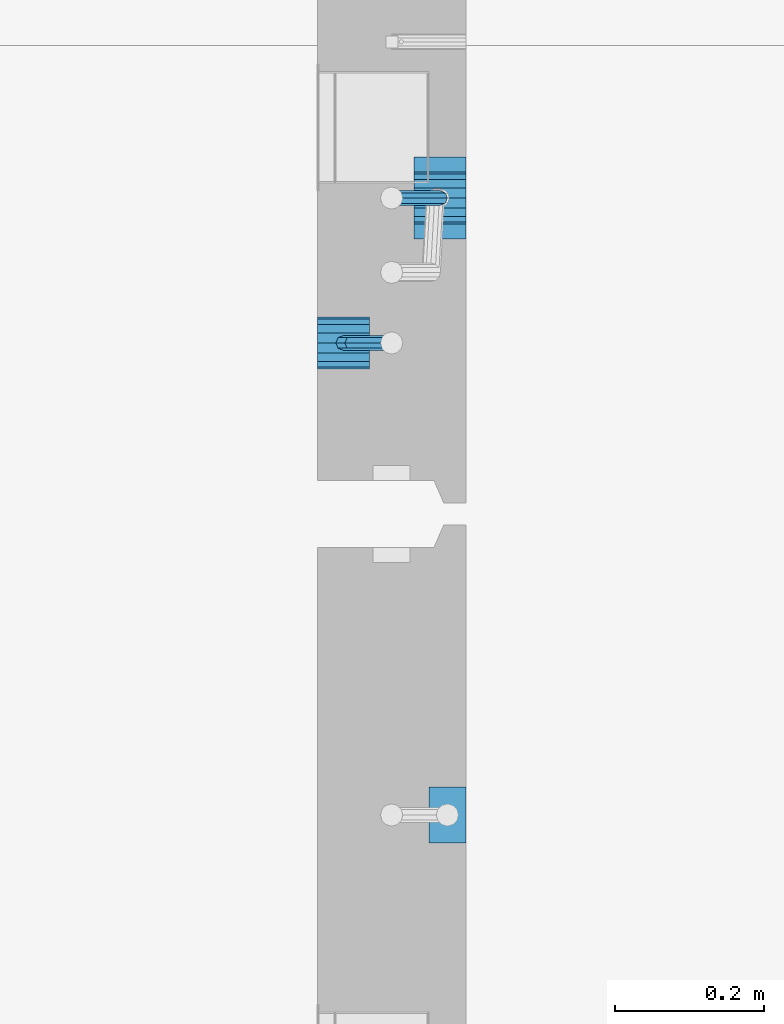
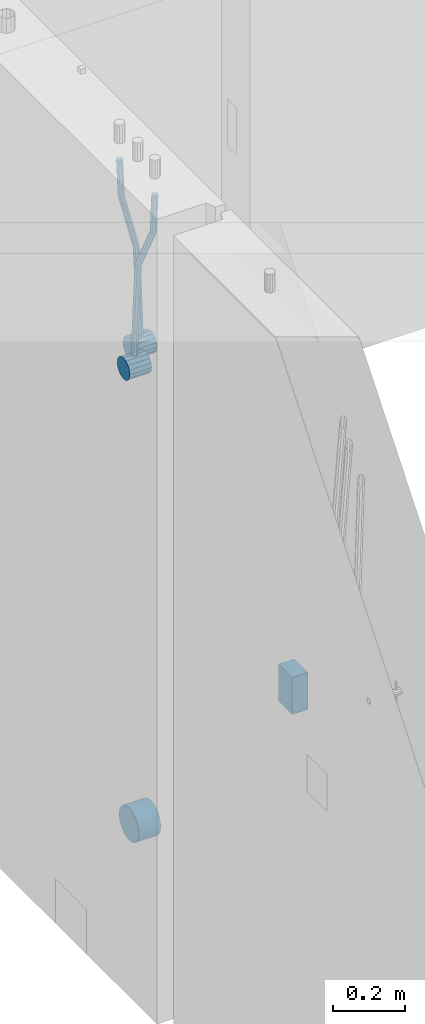
# One storey, part 148 of 350: 6 beams, 2 elements without a shape of their own.
"""IFC2X3 building model written with IfcOpenShell, lengths in millimetres."""

from ifc_helpers import new_model, si_unit, frame, origin_with_axes, place, context, subcontext, project, spatial, faceted_brep, material, type_object, element, aggregate, save


model = new_model("IFC2X3")

# Units and contexts
model_context = context("Model", 3, precision=1e-05, world=origin_with_axes())
body_context = subcontext(model_context, "Body", "Model", "MODEL_VIEW")
ifc_project = project(units=[si_unit("LENGTHUNIT", "METRE", prefix="MILLI"), si_unit("AREAUNIT", "SQUARE_METRE"), si_unit("VOLUMEUNIT", "CUBIC_METRE"), si_unit("MASSUNIT", "GRAM", prefix="KILO"), si_unit("TIMEUNIT", "SECOND"), si_unit("PLANEANGLEUNIT", "RADIAN"), si_unit("SOLIDANGLEUNIT", "STERADIAN"), si_unit("THERMODYNAMICTEMPERATUREUNIT", "DEGREE_CELSIUS"), si_unit("LUMINOUSINTENSITYUNIT", "LUMEN")], contexts=[model_context])

# Site, building, storey
site_placement = place(None, origin_with_axes())
site = spatial("IfcSite", under=ifc_project, at=site_placement, CompositionType="ELEMENT")
building_placement = place(site_placement, origin_with_axes())
building = spatial("IfcBuilding", under=site, at=building_placement, CompositionType="ELEMENT")
storey_placement = place(building_placement, origin_with_axes())
storey = spatial("IfcBuildingStorey", under=building, at=storey_placement, Name="2", CompositionType="ELEMENT", Elevation=0.0)

# Assembly, beams
assembly_1_placement = place(storey_placement, origin_with_axes())
assembly_1 = element("IfcElementAssembly", 1, at=assembly_1_placement, inside=storey, AssemblyPlace="NOTDEFINED", PredefinedType="REINFORCEMENT_UNIT")
ifc_material = material()
beam_type_1 = type_object("IfcBeamType", Name="D20", PredefinedType="NOTDEFINED")
beam_1_placement = place(assembly_1_placement, frame((21875.0000022791, 12925.0000000039, 86795.0), z_axis=(-0.999642804636942, -0.000205726999925762, -0.0267249099902983), x_axis=(-0.0267249099948371, 4.30000201934385e-08, 0.999642825806181)))
beam_1 = element("IfcBeam", 2, at=beam_1_placement, type_object=beam_type_1, material=ifc_material, Name="JM20", ObjectType="D20", context=body_context, shape_type="Brep", body=[
    faceted_brep([(0.0, -10.0, 0.0), (-4.19531716033816e-08, -7.07106781186667, -7.07106781187031), (60.4266690400545, -7.0710677960451, -7.07106780570757), (60.4266690441291, -9.99999998418934, 6.15546014159918e-09), (0.0, 0.0, -10.0), (60.426669036824, 1.58106558956206e-08, -9.99999999384454), (4.196772351861e-08, 7.07106781186303, -7.07106781186667), (60.4266690363438, 7.07106782768096, -7.07106780570757), (0.0, 10.0, 0.0), (60.4266690388904, 10.0000000158179, 6.15182216279209e-09), (4.196772351861e-08, 7.07106781185939, 7.07106781185939), (60.4266690429649, 7.07106782768096, 7.07106781802577), (0.0, 0.0, 10.0), (60.4266690461809, 1.58179318532348e-08, 10.0000000061555), (-4.19531716033816e-08, -7.07106781187031, 7.07106781185939), (60.4266690466611, -7.07106779605238, 7.07106781802213), (61.0378400410118, -7.07106779588503, -7.07106780564936), (60.991799419251, -9.99999998403655, 6.21366780251265e-09), (61.0569027789461, 1.5985278878361e-08, -9.99999999378269), (61.0378209396877, 7.07106782784831, -7.07106780564936), (60.9917724058905, 10.0000000159635, 6.21366780251265e-09), (60.9457317841297, 7.07106782781193, 7.0710678180767), (60.9266690461809, 1.59488990902901e-08, 10.0000000062028), (60.9457508854539, -7.07106779591413, 7.0710678180767), (61.6489592143771, -7.07106614513759, -7.06310863441468), (61.5568818710308, -9.9999984576425, 0.00735959856683621), (61.6870830769039, 1.71821739058942e-06, -9.99179257185824), (61.6489210170112, 7.07106947854481, -7.06310888312146), (61.556827851804, 10.0000015422847, 0.00735924683976918), (61.4647505084577, 7.07106922979438, 7.07782747982128), (61.4266266459163, 1.36643211590126e-06, 10.0065114172685), (61.464788705809, -7.07106639389531, 7.07782772852806), (176.543135720174, -7.07075579406956, -5.56673531796696), (176.451058376813, -9.99968810657447, 1.50373291501455), (176.581259582701, 0.000312069292704109, -8.49541925541052), (176.543097522794, 7.07137982961285, -5.56673556667374), (176.451004357587, 10.00031189336, 1.50373256329476), (176.35892701424, 7.07137958085514, 8.57420079627263), (176.320803151699, 0.000311717507429421, 11.5028847337162), (176.358965211621, -7.07075604281999, 8.57420104497578), (177.098753836006, -7.07075429323595, -5.55949898843028), (176.98362511232, -9.99968666800123, 1.510669025065), (177.146421932586, 0.000313595905026887, -8.48805862247536), (177.098706077581, 7.07138133041735, -5.55949936166144), (176.983557571715, 10.0003133318824, 1.51066849724157), (176.868428848029, 7.07138095712435, 8.58083651073321), (176.820760751449, 0.000313067976094317, 11.5093961447819), (176.868476606425, -7.07075466652896, 8.58083688396073), (177.654312950661, -7.07075204110879, -5.54863964998367), (177.516135294456, -9.99968450931192, 1.52107783331303), (177.711524267797, 0.000315886711177882, -8.47701274570863), (177.654255632195, 7.07138358250813, -5.54864021007961), (177.516054233929, 10.0003154905207, 1.5210770412159), (177.377876577739, 7.0713830223176, 8.59079452451624), (177.320665260588, 0.000315094497636892, 11.5191676202448), (177.377933896176, -7.07075260129932, 8.59079508461218), (298.592214475648, -7.07025824167067, -3.18470470795364), (298.454036904819, -9.99919071054683, 3.88501277673276), (298.649425586758, 0.000809686429420253, -6.11307780703646), (298.592156745173, 7.07187738194261, -3.18470527475802), (298.453955261604, 10.0008092892858, 3.88501197515143), (298.315777690761, 7.07187682041331, 10.9547294598378), (298.258566579665, 0.000808892309578368, 13.883102558917), (298.31583542125, -7.07025880319998, 10.9547300266422), (300.829882012156, -7.07024910539985, -3.14096572775816), (299.972022738802, -9.99918451269514, 3.91468436611831), (301.18507173346, 0.000820039333120803, -6.0635143331092), (300.829526581147, 7.07188651699835, -3.14097211362241), (299.971520083447, 10.0008154854204, 3.91467533514515), (299.113660810108, 7.07188007812692, 10.9703254290253), (298.758471088819, 0.000810933392131119, 13.8928740343799), (299.114016241103, -7.07025554427128, 10.9703318148859), (303.012825988379, -7.0701468967527, -2.64717965084128), (301.452885279024, -9.99911517653163, 4.24965828764471), (303.65870706641, 0.000935858577577164, -5.50397331873319), (303.012180137302, 7.07198871204673, -2.64725173027909), (301.451971907663, 10.0008848023517, 4.24955635192964), (299.892031198324, 7.07191652257279, 11.1463942904193), (299.246150120278, 0.000833767242511385, 14.0031879583075), (299.892677049385, -7.07021908622846, 11.1464663698534), (490.480206458145, -7.06136939830685, 39.7582981627347), (488.920265748791, -9.9903376780876, 46.6551361012243), (491.126087536177, 0.00971335702342913, 36.9015044948464), (490.479560607055, 7.0807662104944, 39.7582260832969), (488.91935237743, 10.0096623007976, 46.6550341655056), (487.359411668076, 7.08069402101864, 53.5518721039953), (486.713530590045, 0.00961126568654436, 56.4086657718872), (487.360057519167, -7.06144158778261, 53.5519441834331), (491.222094319732, -7.06133466202664, 39.9261146072568), (490.367102775039, -9.9902699350514, 46.9824133868096), (491.613766567636, 0.0097361908719904, 37.0118184187741), (491.312683227967, 7.08080521851844, 39.9466800038063), (490.495214837676, 10.0097360849959, 47.0114972495248), (489.640223292983, 7.08080081197113, 54.0677960290814), (489.248551045079, 0.00972995907250152, 56.9820922175604), (489.549634384748, -7.06133906857212, 54.0472306325282), (491.98259360576, -7.07125184727738, 39.9362361015701), (491.850235984879, -10.009610527557, 47.0021524248696), (492.113679795017, 0.00321714190249622, 37.0184717700395), (492.166706040836, 7.06966845271199, 39.958046203883), (492.110610287549, 9.988670745126, 47.0329965673554), (491.978252666668, 7.05031206484455, 54.0989128906476), (491.847166477397, -0.0241569243353297, 57.0166772221819), (491.794140231592, -7.09060823514483, 54.077102788342), (512.839684553823, -7.34323584322192, 40.2138233804726), (512.707326932941, -10.2815945235034, 47.2797397037684), (512.970770743079, -0.268766854042042, 37.296059048942), (513.023796988884, 6.79768445676746, 40.2356334827819), (512.967701235597, 9.71668674918146, 47.3105838462543), (512.83534361473, 6.77832806890183, 54.3765001695538), (512.704257425459, -0.296140920279868, 57.2942645010808), (512.651231179654, -7.36259223108937, 54.3546900672372), (513.475042066755, -7.35152113457298, 40.2222793613946), (513.367413171509, -10.2902022863618, 47.2885247996019), (513.548971693657, -0.276306803183616, 37.3037543324754), (513.545895079456, 6.79087610917486, 40.2425820926655), (513.467614462992, 9.71016770021379, 47.3172371975234), (513.359985567746, 6.77148654842495, 54.3834826357306), (513.286055940844, -0.303727782968053, 57.3020076646499), (513.289132555044, -7.37091069532653, 54.3631799044524), (514.110453382629, -7.34964673829199, 40.2305416874733), (514.027555144421, -10.2882337755309, 47.2971163788461), (514.127221878356, -0.274611275939606, 37.3112548247955), (514.06803787424, 6.7924127919523, 40.249334442502), (513.967570557215, 9.71165861202826, 47.3236933478729), (513.884672319007, 6.77307157479117, 54.3902680392421), (513.867903823266, -0.301963887563034, 57.3095549019235), (513.927087827382, -7.36898795545494, 54.3714752842207), (614.131240716772, -7.05138387012084, 41.5279197320488), (614.048342478563, -9.98997090735793, 48.5944944234179), (614.148009212484, 0.0236515922315448, 38.6086328693636), (614.088825208368, 7.09067566012527, 41.5467124870702), (613.988357891343, 10.0099214802012, 48.6210713924484), (613.905459653135, 7.07133444296232, 55.6876460838175), (613.888691157408, -0.00370101939006418, 58.606932946499), (613.947875161524, -7.07072508728379, 55.6688533287888)], [[[0, 1, 2, 3]], [[1, 4, 5, 2]], [[4, 6, 7, 5]], [[6, 8, 9, 7]], [[8, 10, 11, 9]], [[10, 12, 13, 11]], [[12, 14, 15, 13]], [[14, 0, 3, 15]], [[14, 12, 10, 8, 6, 4, 1, 0]], [[3, 2, 16, 17]], [[2, 5, 18, 16]], [[5, 7, 19, 18]], [[7, 9, 20, 19]], [[9, 11, 21, 20]], [[11, 13, 22, 21]], [[13, 15, 23, 22]], [[15, 3, 17, 23]], [[17, 16, 24, 25]], [[16, 18, 26, 24]], [[18, 19, 27, 26]], [[19, 20, 28, 27]], [[20, 21, 29, 28]], [[21, 22, 30, 29]], [[22, 23, 31, 30]], [[23, 17, 25, 31]], [[25, 24, 32, 33]], [[24, 26, 34, 32]], [[26, 27, 35, 34]], [[27, 28, 36, 35]], [[28, 29, 37, 36]], [[29, 30, 38, 37]], [[30, 31, 39, 38]], [[31, 25, 33, 39]], [[33, 32, 40, 41]], [[32, 34, 42, 40]], [[34, 35, 43, 42]], [[35, 36, 44, 43]], [[36, 37, 45, 44]], [[37, 38, 46, 45]], [[38, 39, 47, 46]], [[39, 33, 41, 47]], [[41, 40, 48, 49]], [[40, 42, 50, 48]], [[42, 43, 51, 50]], [[43, 44, 52, 51]], [[44, 45, 53, 52]], [[45, 46, 54, 53]], [[46, 47, 55, 54]], [[47, 41, 49, 55]], [[49, 48, 56, 57]], [[48, 50, 58, 56]], [[50, 51, 59, 58]], [[51, 52, 60, 59]], [[52, 53, 61, 60]], [[53, 54, 62, 61]], [[54, 55, 63, 62]], [[55, 49, 57, 63]], [[57, 56, 64, 65]], [[56, 58, 66, 64]], [[58, 59, 67, 66]], [[59, 60, 68, 67]], [[60, 61, 69, 68]], [[61, 62, 70, 69]], [[62, 63, 71, 70]], [[63, 57, 65, 71]], [[65, 64, 72, 73]], [[64, 66, 74, 72]], [[66, 67, 75, 74]], [[67, 68, 76, 75]], [[68, 69, 77, 76]], [[69, 70, 78, 77]], [[70, 71, 79, 78]], [[71, 65, 73, 79]], [[73, 72, 80, 81]], [[72, 74, 82, 80]], [[74, 75, 83, 82]], [[75, 76, 84, 83]], [[76, 77, 85, 84]], [[77, 78, 86, 85]], [[78, 79, 87, 86]], [[79, 73, 81, 87]], [[81, 80, 88, 89]], [[80, 82, 90, 88]], [[82, 83, 91, 90]], [[83, 84, 92, 91]], [[84, 85, 93, 92]], [[85, 86, 94, 93]], [[86, 87, 95, 94]], [[87, 81, 89, 95]], [[89, 88, 96, 97]], [[88, 90, 98, 96]], [[90, 91, 99, 98]], [[91, 92, 100, 99]], [[92, 93, 101, 100]], [[93, 94, 102, 101]], [[94, 95, 103, 102]], [[95, 89, 97, 103]], [[97, 96, 104, 105]], [[96, 98, 106, 104]], [[98, 99, 107, 106]], [[99, 100, 108, 107]], [[100, 101, 109, 108]], [[101, 102, 110, 109]], [[102, 103, 111, 110]], [[103, 97, 105, 111]], [[105, 104, 112, 113]], [[104, 106, 114, 112]], [[106, 107, 115, 114]], [[107, 108, 116, 115]], [[108, 109, 117, 116]], [[109, 110, 118, 117]], [[110, 111, 119, 118]], [[111, 105, 113, 119]], [[113, 112, 120, 121]], [[112, 114, 122, 120]], [[114, 115, 123, 122]], [[115, 116, 124, 123]], [[116, 117, 125, 124]], [[117, 118, 126, 125]], [[118, 119, 127, 126]], [[119, 113, 121, 127]], [[121, 120, 128, 129]], [[120, 122, 130, 128]], [[122, 123, 131, 130]], [[123, 124, 132, 131]], [[124, 125, 133, 132]], [[125, 126, 134, 133]], [[126, 127, 135, 134]], [[127, 121, 129, 135]], [[130, 131, 132, 133, 134, 135, 129, 128]]]),
])
beam_2_placement = place(assembly_1_placement, frame((21744.9999977209, 12729.9999999961, 86890.0), z_axis=(0.999642804629538, 0.000205762999925497, -0.0267249099901003), x_axis=(0.0267249109941254, -4.30000210532798e-08, 0.999642825779465)))
beam_2 = element("IfcBeam", 3, at=beam_2_placement, type_object=beam_type_1, material=ifc_material, Name="JM20", ObjectType="D20", context=body_context, shape_type="Brep", body=[
    faceted_brep([(0.0, -10.0, 0.0), (-4.19531716033816e-08, -7.07106781186667, -7.07106781187031), (60.4266690400545, -7.0710677960451, -7.07106780570757), (60.4266690441291, -9.99999998418934, 6.15546014159918e-09), (0.0, 0.0, -10.0), (60.426669036824, 1.58106558956206e-08, -9.99999999384454), (4.196772351861e-08, 7.07106781186303, -7.07106781186667), (60.4266690363438, 7.07106782768096, -7.07106780570757), (0.0, 10.0, 0.0), (60.4266690388904, 10.0000000158179, 6.15182216279209e-09), (4.196772351861e-08, 7.07106781185939, 7.07106781185939), (60.4266690429649, 7.07106782768096, 7.07106781802577), (0.0, 0.0, 10.0), (60.4266690461809, 1.58179318532348e-08, 10.0000000061555), (-4.19531716033816e-08, -7.07106781187031, 7.07106781185939), (60.4266690466611, -7.07106779605238, 7.07106781802213), (61.0378400410118, -7.07106779588503, -7.07106780564936), (60.991799419251, -9.99999998403655, 6.21366780251265e-09), (61.0569027789461, 1.5985278878361e-08, -9.99999999378269), (61.0378209396877, 7.07106782784831, -7.07106780564936), (60.9917724058905, 10.0000000159635, 6.21366780251265e-09), (60.9457317841297, 7.07106782781193, 7.0710678180767), (60.9266690461809, 1.59488990902901e-08, 10.0000000062028), (60.9457508854539, -7.07106779591413, 7.0710678180767), (61.6489592143771, -7.07106614513759, -7.06310863441468), (61.5568818710308, -9.9999984576425, 0.00735959856683621), (61.6870830769039, 1.71821739058942e-06, -9.99179257185824), (61.6489210170112, 7.07106947854481, -7.06310888312146), (61.556827851804, 10.0000015422847, 0.00735924683976918), (61.4647505084577, 7.07106922979438, 7.07782747982128), (61.4266266459163, 1.36643211590126e-06, 10.0065114172685), (61.464788705809, -7.07106639389531, 7.07782772852806), (176.543135720174, -7.07075579406956, -5.56673531796696), (176.451058376813, -9.99968810657447, 1.50373291501455), (176.581259582701, 0.000312069292704109, -8.49541925541052), (176.543097522794, 7.07137982961285, -5.56673556667374), (176.451004357587, 10.00031189336, 1.50373256329476), (176.35892701424, 7.07137958085514, 8.57420079627263), (176.320803151699, 0.000311717507429421, 11.5028847337162), (176.358965211621, -7.07075604281999, 8.57420104497578), (177.098753836006, -7.07075429323595, -5.55949898843028), (176.98362511232, -9.99968666800123, 1.510669025065), (177.146421932586, 0.000313595905026887, -8.48805862247536), (177.098706077581, 7.07138133041735, -5.55949936166144), (176.983557571715, 10.0003133318824, 1.51066849724157), (176.868428848029, 7.07138095712435, 8.58083651073321), (176.820760751449, 0.000313067976094317, 11.5093961447819), (176.868476606425, -7.07075466652896, 8.58083688396073), (177.654312950661, -7.07075204110879, -5.54863964998367), (177.516135294456, -9.99968450931192, 1.52107783331303), (177.711524267797, 0.000315886711177882, -8.47701274570863), (177.654255632195, 7.07138358250813, -5.54864021007961), (177.516054233929, 10.0003154905207, 1.5210770412159), (177.377876577739, 7.0713830223176, 8.59079452451624), (177.320665260588, 0.000315094497636892, 11.5191676202448), (177.377933896176, -7.07075260129932, 8.59079508461218), (297.446964549832, -7.07026642590426, -3.20709054437975), (297.308786893627, -9.99919889410376, 3.86262693891331), (297.504175866998, 0.000801501919340808, -6.13546364010836), (297.44690723141, 7.07186919770902, -3.20709110447569), (297.308705833115, 10.0008011057289, 3.86262614682164), (297.170528176895, 7.07186863752577, 10.9323436301165), (297.113316859759, 0.000800709702161839, 13.8607167258415), (297.170585495318, -7.07026698608752, 10.9323441902106), (301.63986343499, -7.07024942873613, -3.12513327486886), (299.972259732356, -9.99918809692099, 3.91468900081236), (302.330321453323, 0.000821066147182137, -6.04112849743797), (301.639172844472, 7.07188619231601, -3.12514621333321), (299.971283089879, 10.0008118992846, 3.91467070306135), (298.303679387245, 7.07187323109611, 10.9544929787371), (297.613221368898, 0.000802736216428457, 13.870488201308), (298.304369977734, -7.0702623899524, 10.9545059172033), (305.4239078393, -7.06987516590743, -1.31733741553398), (302.376014215231, -9.99895035236841, 5.06306278734701), (306.685863931343, 0.00125185327851796, -3.96030416885333), (305.422645727784, 7.07226039861052, -1.31762339341367), (302.374229320019, 10.0010495638962, 5.06265835355225), (299.326335695951, 7.07197437743162, 11.4430585564332), (298.064379603893, 0.000847358245664509, 14.0860253097508), (299.327597807453, -7.07016118708634, 11.4433445343111), (396.081143409523, -7.0609086662007, 41.9934056867296), (393.033249785469, -9.98998385266168, 48.3738058896106), (397.34309950161, 0.0102183529888862, 39.3504389334103), (396.079881298036, 7.08122689832453, 41.9931197088481), (393.031464890271, 10.0100160636066, 48.3734014558122), (389.983571266188, 7.08094087714562, 54.753801658695), (388.72161517413, 0.00981385795967071, 57.3967684120162), (389.984833377704, -7.06119468737961, 54.7540876365765), (397.068790959223, -7.06081098241702, 42.4652461198857), (395.403898118791, -9.98974938248648, 49.5063634875187), (397.79425773659, 0.0102629750217602, 39.565976041853), (397.155329851754, 7.08133326610914, 42.5069063441551), (395.526282594277, 10.0102628148125, 49.5652799416912), (393.861389753831, 7.08132441474299, 56.606397309326), (393.135922976478, 0.0102504573078477, 59.5056673873569), (393.774850861315, -7.06081983378317, 56.5647370850584), (398.163169908337, -7.0750819080713, 42.4798112226927), (398.030733605352, -10.0240038552729, 49.541324073105), (398.294170965004, 0.00374400413056719, 39.572629393122), (398.346998133013, 7.06579366763617, 42.5227662718698), (398.290705973835, 9.97421416771613, 49.6020716862276), (398.15826967085, 7.02529222051089, 56.6635845366436), (398.027268614198, -0.0535336916836968, 59.5707663662142), (397.974441446175, -7.11558335519294, 56.6206294874646), (417.87389934808, -7.33211385723553, 42.7421415616409), (417.741463045095, -10.2810358044335, 49.803654412055), (418.004900404732, -0.253287945030024, 39.8349597320685), (418.057727572756, 6.8087617184683, 42.7850966108181), (418.001435413564, 9.71718221855917, 49.8644020251777), (417.868999110593, 6.76826027135394, 56.92591487559), (417.737998053926, -0.310565640847926, 59.8330967051625), (417.685170885918, -7.37261530435353, 56.8829598264128), (418.509166047603, -7.3403978651113, 42.7505963339045), (418.401542092906, -10.2896433704191, 49.812439412166), (418.582978010687, -0.260826195415575, 39.8426533739894), (418.579739935274, 6.80195457034279, 42.7920440797316), (418.501348641992, 9.71066324766434, 49.8710553764413), (418.393724687281, 6.76141774235657, 56.9328984547028), (418.319912724211, -0.318153927339154, 59.8408414146197), (418.323150799639, -7.38093469310479, 56.8914507088775), (419.144486528079, -7.33852513420788, 42.7588588031304), (419.061676848418, -10.2876749343814, 49.821032815089), (419.161104845465, -0.25913295731516, 39.8501522177412), (419.101797015624, 6.80348967242753, 42.7987939276718), (419.00130476091, 9.71215420445515, 49.8775096098252), (418.918495081249, 6.76300440428531, 56.9396836217802), (418.901876763863, -0.316387772607413, 59.8483902071712), (418.961184593718, -7.37901040236102, 56.8997484972406), (519.165277458538, -7.04026297675227, 44.0562368946885), (519.082467778877, -9.98941277692575, 51.1184109066417), (519.181895775939, 0.0391292001404508, 41.1475303092957), (519.122587946098, 7.10175182989406, 44.0961720192245), (519.022095691384, 10.0104163619108, 51.1748877013797), (518.939286011722, 7.06126656174456, 58.2370617133347), (518.922667694336, -0.0181256151481648, 61.1457682987275), (518.981975524162, -7.08074824490541, 58.1971265887951)], [[[0, 1, 2, 3]], [[1, 4, 5, 2]], [[4, 6, 7, 5]], [[6, 8, 9, 7]], [[8, 10, 11, 9]], [[10, 12, 13, 11]], [[12, 14, 15, 13]], [[14, 0, 3, 15]], [[14, 12, 10, 8, 6, 4, 1, 0]], [[3, 2, 16, 17]], [[2, 5, 18, 16]], [[5, 7, 19, 18]], [[7, 9, 20, 19]], [[9, 11, 21, 20]], [[11, 13, 22, 21]], [[13, 15, 23, 22]], [[15, 3, 17, 23]], [[17, 16, 24, 25]], [[16, 18, 26, 24]], [[18, 19, 27, 26]], [[19, 20, 28, 27]], [[20, 21, 29, 28]], [[21, 22, 30, 29]], [[22, 23, 31, 30]], [[23, 17, 25, 31]], [[25, 24, 32, 33]], [[24, 26, 34, 32]], [[26, 27, 35, 34]], [[27, 28, 36, 35]], [[28, 29, 37, 36]], [[29, 30, 38, 37]], [[30, 31, 39, 38]], [[31, 25, 33, 39]], [[33, 32, 40, 41]], [[32, 34, 42, 40]], [[34, 35, 43, 42]], [[35, 36, 44, 43]], [[36, 37, 45, 44]], [[37, 38, 46, 45]], [[38, 39, 47, 46]], [[39, 33, 41, 47]], [[41, 40, 48, 49]], [[40, 42, 50, 48]], [[42, 43, 51, 50]], [[43, 44, 52, 51]], [[44, 45, 53, 52]], [[45, 46, 54, 53]], [[46, 47, 55, 54]], [[47, 41, 49, 55]], [[49, 48, 56, 57]], [[48, 50, 58, 56]], [[50, 51, 59, 58]], [[51, 52, 60, 59]], [[52, 53, 61, 60]], [[53, 54, 62, 61]], [[54, 55, 63, 62]], [[55, 49, 57, 63]], [[57, 56, 64, 65]], [[56, 58, 66, 64]], [[58, 59, 67, 66]], [[59, 60, 68, 67]], [[60, 61, 69, 68]], [[61, 62, 70, 69]], [[62, 63, 71, 70]], [[63, 57, 65, 71]], [[65, 64, 72, 73]], [[64, 66, 74, 72]], [[66, 67, 75, 74]], [[67, 68, 76, 75]], [[68, 69, 77, 76]], [[69, 70, 78, 77]], [[70, 71, 79, 78]], [[71, 65, 73, 79]], [[73, 72, 80, 81]], [[72, 74, 82, 80]], [[74, 75, 83, 82]], [[75, 76, 84, 83]], [[76, 77, 85, 84]], [[77, 78, 86, 85]], [[78, 79, 87, 86]], [[79, 73, 81, 87]], [[81, 80, 88, 89]], [[80, 82, 90, 88]], [[82, 83, 91, 90]], [[83, 84, 92, 91]], [[84, 85, 93, 92]], [[85, 86, 94, 93]], [[86, 87, 95, 94]], [[87, 81, 89, 95]], [[89, 88, 96, 97]], [[88, 90, 98, 96]], [[90, 91, 99, 98]], [[91, 92, 100, 99]], [[92, 93, 101, 100]], [[93, 94, 102, 101]], [[94, 95, 103, 102]], [[95, 89, 97, 103]], [[97, 96, 104, 105]], [[96, 98, 106, 104]], [[98, 99, 107, 106]], [[99, 100, 108, 107]], [[100, 101, 109, 108]], [[101, 102, 110, 109]], [[102, 103, 111, 110]], [[103, 97, 105, 111]], [[105, 104, 112, 113]], [[104, 106, 114, 112]], [[106, 107, 115, 114]], [[107, 108, 116, 115]], [[108, 109, 117, 116]], [[109, 110, 118, 117]], [[110, 111, 119, 118]], [[111, 105, 113, 119]], [[113, 112, 120, 121]], [[112, 114, 122, 120]], [[114, 115, 123, 122]], [[115, 116, 124, 123]], [[116, 117, 125, 124]], [[117, 118, 126, 125]], [[118, 119, 127, 126]], [[119, 113, 121, 127]], [[121, 120, 128, 129]], [[120, 122, 130, 128]], [[122, 123, 131, 130]], [[123, 124, 132, 131]], [[124, 125, 133, 132]], [[125, 126, 134, 133]], [[126, 127, 135, 134]], [[127, 121, 129, 135]], [[130, 131, 132, 133, 134, 135, 129, 128]]]),
])
beam_type_2 = type_object("IfcBeamType", Name="D70", PredefinedType="NOTDEFINED")
beam_3_placement = place(assembly_1_placement, frame((21839.9999977209, 12925.0, 86760.0), z_axis=(0.0, 0.0, 1.0), x_axis=(1.0, 0.0, 0.0)))
beam_3 = element("IfcBeam", 4, at=beam_3_placement, type_object=beam_type_2, material=ifc_material, ObjectType="D70", context=body_context, shape_type="Brep", body=[
    faceted_brep([(0.0, -35.0, 0.0), (0.0, -32.3357836378964, -13.3939201327739), (70.0, -32.3357836378964, -13.3939201327739), (70.0, -35.0, 0.0), (0.0, -24.7487373415279, -24.7487373415352), (70.0, -24.7487373415279, -24.7487373415352), (0.0, -13.3939201327776, -32.3357836379), (70.0, -13.3939201327776, -32.3357836379), (0.0, 0.0, -35.0), (70.0, 0.0, -35.0), (0.0, 13.3939201327776, -32.3357836379), (70.0, 13.3939201327776, -32.3357836379), (0.0, 24.7487373415279, -24.7487373415352), (70.0, 24.7487373415279, -24.7487373415352), (0.0, 32.3357836378964, -13.3939201327739), (70.0, 32.3357836378964, -13.3939201327739), (0.0, 35.0, 0.0), (70.0, 35.0, 0.0), (0.0, 32.3357836378964, 13.3939201327739), (70.0, 32.3357836378964, 13.3939201327739), (0.0, 24.7487373415279, 24.7487373415352), (70.0, 24.7487373415279, 24.7487373415352), (0.0, 13.3939201327776, 32.3357836379), (70.0, 13.3939201327776, 32.3357836379), (0.0, 0.0, 35.0), (70.0, 0.0, 35.0), (0.0, -13.3939201327776, 32.3357836379), (70.0, -13.3939201327776, 32.3357836379), (0.0, -24.7487373415279, 24.7487373415352), (70.0, -24.7487373415279, 24.7487373415352), (0.0, -32.3357836378964, 13.3939201327739), (70.0, -32.3357836378964, 13.3939201327739)], [[[0, 1, 2, 3]], [[1, 4, 5, 2]], [[4, 6, 7, 5]], [[6, 8, 9, 7]], [[8, 10, 11, 9]], [[10, 12, 13, 11]], [[12, 14, 15, 13]], [[14, 16, 17, 15]], [[16, 18, 19, 17]], [[18, 20, 21, 19]], [[20, 22, 23, 21]], [[22, 24, 25, 23]], [[24, 26, 27, 25]], [[26, 28, 29, 27]], [[28, 30, 31, 29]], [[30, 0, 3, 31]], [[5, 7, 9, 11, 13, 15, 17, 19, 21, 23, 25, 27, 29, 31, 3, 2]], [[30, 28, 26, 24, 22, 20, 18, 16, 14, 12, 10, 8, 6, 4, 1, 0]]]),
])
beam_4_placement = place(assembly_1_placement, frame((21709.9999977209, 12730.0, 86855.0), z_axis=(0.0, 0.0, 1.0), x_axis=(1.0, 0.0, 0.0)))
beam_4 = element("IfcBeam", 5, at=beam_4_placement, type_object=beam_type_2, material=ifc_material, ObjectType="D70", context=body_context, shape_type="Brep", body=[
    faceted_brep([(0.0, -35.0, 0.0), (0.0, -32.3357836378964, -13.3939201327739), (70.0, -32.3357836378964, -13.3939201327739), (70.0, -35.0, 0.0), (0.0, -24.7487373415279, -24.7487373415352), (70.0, -24.7487373415279, -24.7487373415352), (0.0, -13.3939201327776, -32.3357836379), (70.0, -13.3939201327776, -32.3357836379), (0.0, 0.0, -35.0), (70.0, 0.0, -35.0), (0.0, 13.3939201327776, -32.3357836379), (70.0, 13.3939201327776, -32.3357836379), (0.0, 24.7487373415279, -24.7487373415352), (70.0, 24.7487373415279, -24.7487373415352), (0.0, 32.3357836378964, -13.3939201327739), (70.0, 32.3357836378964, -13.3939201327739), (0.0, 35.0, 0.0), (70.0, 35.0, 0.0), (0.0, 32.3357836378964, 13.3939201327739), (70.0, 32.3357836378964, 13.3939201327739), (0.0, 24.7487373415279, 24.7487373415352), (70.0, 24.7487373415279, 24.7487373415352), (0.0, 13.3939201327776, 32.3357836379), (70.0, 13.3939201327776, 32.3357836379), (0.0, 0.0, 35.0), (70.0, 0.0, 35.0), (0.0, -13.3939201327776, 32.3357836379), (70.0, -13.3939201327776, 32.3357836379), (0.0, -24.7487373415279, 24.7487373415352), (70.0, -24.7487373415279, 24.7487373415352), (0.0, -32.3357836378964, 13.3939201327739), (70.0, -32.3357836378964, 13.3939201327739)], [[[0, 1, 2, 3]], [[1, 4, 5, 2]], [[4, 6, 7, 5]], [[6, 8, 9, 7]], [[8, 10, 11, 9]], [[10, 12, 13, 11]], [[12, 14, 15, 13]], [[14, 16, 17, 15]], [[16, 18, 19, 17]], [[18, 20, 21, 19]], [[20, 22, 23, 21]], [[22, 24, 25, 23]], [[24, 26, 27, 25]], [[26, 28, 29, 27]], [[28, 30, 31, 29]], [[30, 0, 3, 31]], [[5, 7, 9, 11, 13, 15, 17, 19, 21, 23, 25, 27, 29, 31, 3, 2]], [[30, 28, 26, 24, 22, 20, 18, 16, 14, 12, 10, 8, 6, 4, 1, 0]]]),
])
beam_type_3 = type_object("IfcBeamType", Name="D110", PredefinedType="NOTDEFINED")
beam_5_placement = place(assembly_1_placement, frame((21910.0000022791, 12925.0, 85155.0), z_axis=(0.0, 0.0, 1.0), x_axis=(-1.0, 3.00000001838171e-08, 0.0)))
beam_5 = element("IfcBeam", 6, at=beam_5_placement, type_object=beam_type_3, material=ifc_material, ObjectType="D110", context=body_context, shape_type="Brep", body=[
    faceted_brep([(0.0, -55.0, 0.0), (0.0, -52.3081083962352, -16.9959346906253), (70.0, -52.3081083962352, -16.9959346906253), (70.0, -55.0, 0.0), (0.0, -44.4959346906217, -32.328188876083), (70.0, -44.4959346906217, -32.328188876083), (0.0, -32.3281888760866, -44.4959346906253), (70.0, -32.3281888760866, -44.4959346906253), (0.0, -16.9959346906217, -52.3081083962315), (70.0, -16.9959346906217, -52.3081083962315), (0.0, 0.0, -55.0), (70.0, 0.0, -55.0), (0.0, 16.9959346906217, -52.3081083962315), (70.0, 16.9959346906217, -52.3081083962315), (0.0, 32.3281888760866, -44.4959346906253), (70.0, 32.3281888760866, -44.4959346906253), (0.0, 44.4959346906217, -32.328188876083), (70.0, 44.4959346906217, -32.328188876083), (0.0, 52.3081083962352, -16.9959346906253), (70.0, 52.3081083962352, -16.9959346906253), (0.0, 55.0, 0.0), (70.0, 55.0, 0.0), (0.0, 52.3081083962352, 16.9959346906253), (70.0, 52.3081083962352, 16.9959346906253), (0.0, 44.4959346906217, 32.328188876083), (70.0, 44.4959346906217, 32.328188876083), (0.0, 32.3281888760866, 44.4959346906253), (70.0, 32.3281888760866, 44.4959346906253), (0.0, 16.9959346906217, 52.3081083962315), (70.0, 16.9959346906217, 52.3081083962315), (0.0, 0.0, 55.0), (70.0, 0.0, 55.0), (0.0, -16.9959346906217, 52.3081083962315), (70.0, -16.9959346906217, 52.3081083962315), (0.0, -32.3281888760866, 44.4959346906253), (70.0, -32.3281888760866, 44.4959346906253), (0.0, -44.4959346906217, 32.328188876083), (70.0, -44.4959346906217, 32.328188876083), (0.0, -52.3081083962352, 16.9959346906253), (70.0, -52.3081083962352, 16.9959346906253)], [[[0, 1, 2, 3]], [[1, 4, 5, 2]], [[4, 6, 7, 5]], [[6, 8, 9, 7]], [[8, 10, 11, 9]], [[10, 12, 13, 11]], [[12, 14, 15, 13]], [[14, 16, 17, 15]], [[16, 18, 19, 17]], [[18, 20, 21, 19]], [[20, 22, 23, 21]], [[22, 24, 25, 23]], [[24, 26, 27, 25]], [[26, 28, 29, 27]], [[28, 30, 31, 29]], [[30, 32, 33, 31]], [[32, 34, 35, 33]], [[34, 36, 37, 35]], [[36, 38, 39, 37]], [[38, 0, 3, 39]], [[5, 7, 9, 11, 13, 15, 17, 19, 21, 23, 25, 27, 29, 31, 33, 35, 37, 39, 3, 2]], [[38, 36, 34, 32, 30, 28, 26, 24, 22, 20, 18, 16, 14, 12, 10, 8, 6, 4, 1, 0]]]),
])
aggregate(assembly_1, [beam_1, beam_3, beam_2, beam_4, beam_5])

# Assembly, beam
assembly_2_placement = place(storey_placement, origin_with_axes())
assembly_2 = element("IfcElementAssembly", 7, at=assembly_2_placement, inside=storey, AssemblyPlace="NOTDEFINED", PredefinedType="REINFORCEMENT_UNIT")
beam_type_4 = type_object("IfcBeamType", Name="125X50", PredefinedType="NOTDEFINED")
beam_6_placement = place(assembly_2_placement, frame((21885.0, 12057.5, 86105.0), z_axis=(0.0, 0.0, 1.0), x_axis=(0.0, 1.0, 0.0)))
beam_6 = element("IfcBeam", 8, at=beam_6_placement, type_object=beam_type_4, material=ifc_material, Name="WM1", ObjectType="125X50", context=body_context, shape_type="Brep", body=[
    faceted_brep([(0.0, 25.0, -62.5), (0.0, 25.0, 62.5), (75.0, 25.0, 62.5), (75.0, 25.0, -62.5), (0.0, -25.0, 62.5), (75.0, -25.0, 62.5), (0.0, -25.0, -62.5), (75.0, -25.0, -62.5)], [[[0, 1, 2, 3]], [[1, 4, 5, 2]], [[4, 6, 7, 5]], [[6, 0, 3, 7]], [[5, 7, 3, 2]], [[0, 6, 4, 1]]]),
])
aggregate(assembly_2, [beam_6])

save(model, "model.ifc")
